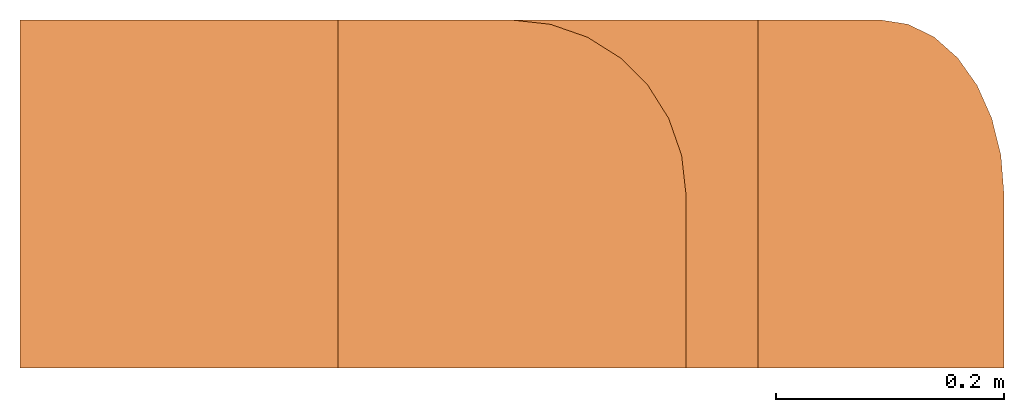
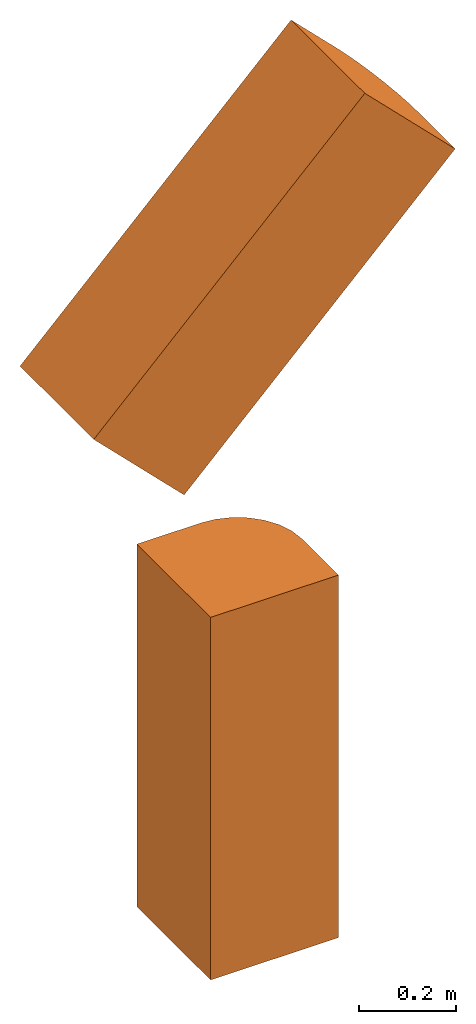
# One storey: 2 proxies.
"""IFC4 building model written with IfcOpenShell, lengths in feet."""

from ifc_helpers import new_model, entity, si_unit, converted_unit, frame, origin_with_axes, place, context, subcontext, project, spatial, polyline, outline, extrude, source, transform, mapped, type_object, element, save


model = new_model("IFC4")

# Units and contexts
model_context = context("Model", 3, precision=1e-05, world=origin_with_axes())
body_context = subcontext(model_context, "Body", "Model", "MODEL_VIEW")
ifc_project = project(units=[converted_unit("LENGTHUNIT", "foot", entity("IfcReal", 0.3048), si_unit("LENGTHUNIT", "METRE"), dimensions=[1, 0, 0, 0, 0, 0, 0]), converted_unit("AREAUNIT", "square foot", entity("IfcReal", 0.0929), si_unit("AREAUNIT", "SQUARE_METRE"), dimensions=[2, 0, 0, 0, 0, 0, 0]), converted_unit("VOLUMEUNIT", "cubic foot", entity("IfcReal", 0.02832), si_unit("VOLUMEUNIT", "CUBIC_METRE"), dimensions=[3, 0, 0, 0, 0, 0, 0])], contexts=[model_context])

# Site, building, storey
site_placement = place(None, origin_with_axes())
site = spatial("IfcSite", under=ifc_project, at=site_placement, CompositionType="ELEMENT")
building_placement = place(site_placement, origin_with_axes())
building = spatial("IfcBuilding", under=site, at=building_placement, CompositionType="ELEMENT")
storey_placement = place(building_placement, origin_with_axes())
storey = spatial("IfcBuildingStorey", under=building, at=storey_placement, Name="Level 1", CompositionType="ELEMENT", Elevation=0.0)

# Proxies
building_element_proxy_type_1 = type_object("IfcBuildingElementProxyType", Name="Generic Models 2:Generic Models 1", PredefinedType="NOTDEFINED")
shared_shape_1 = source(origin_with_axes(), body_context, "Body", "SweptSolid", [
    extrude(outline(polyline([(-0.689908607894667, -0.310091428908463), (-0.189908577271021, -0.310091428908463), (-0.189908577271021, -0.310091428908463), (-0.0786481136725018, -0.297555387059222), (0.0270332877091535, -0.26057586758312), (0.121836328091897, -0.201007155725962), (0.201007155725962, -0.121836328091897), (0.26057586758312, -0.0270332877091535), (0.297555387059222, 0.0786481136725018), (0.310091428908463, 0.189908577271021), (0.310091428908463, 0.189908577271021), (0.310091428908463, 0.689908607894667), (-0.689908607894667, 0.689908607894667), (-0.689908607894667, -0.310091428908463)])), frame((0.189908577271021, 0.189908577271021, 0.0), z_axis=(0.0, 0.0, 1.0), x_axis=(0.0, 1.0, 0.0)), (0.0, 0.0, 0.999999940395355), 2.99999996554402),
])
proxy_1_placement = place(storey_placement, origin_with_axes())
element("IfcBuildingElementProxy", 1, at=proxy_1_placement, inside=storey, type_object=building_element_proxy_type_1, Name="Generic Models 2:Generic Models 1", ObjectType="Generic Models 2:Generic Models 1", PredefinedType="NOTDEFINED", context=body_context, shape_type="MappedRepresentation", body=[
    mapped(shared_shape_1, transform((0.0, 0.0, 0.0), x_axis=(1.0, 0.0, 0.0), y_axis=(0.0, 1.0, 0.0), z_axis=(0.0, 0.0, 1.0), scale=1.0)),
])
building_element_proxy_type_2 = type_object("IfcBuildingElementProxyType", Name="Generic Models 1:Generic Models 1", PredefinedType="NOTDEFINED")
shared_shape_2 = source(origin_with_axes(), body_context, "Body", "SweptSolid", [
    extrude(outline(polyline([(-0.689908656782991, -0.310091477796787), (-0.189908650603507, -0.310091477796787), (-0.189908650603507, -0.310091477796787), (-0.0786481625608259, -0.29755536261506), (0.0270332388208294, -0.260575916471444), (0.121836254759411, -0.201007155725962), (0.2010071312818, -0.121836340313978), (0.260575794250633, -0.0270332999312346), (0.297555313726736, 0.0786481258945828), (0.310091355575977, 0.18990856504894), (0.310091355575977, 0.18990856504894), (0.310091355575977, 0.689908607894667), (-0.689908656782991, 0.689908607894667), (-0.689908656782991, -0.310091477796787)])), frame((0.487839035552943, 0.689908656782991, 0.224501564316549), z_axis=(0.70710676908493, -1.06114219633469e-08, 0.70710676908493), x_axis=(0.0, 1.0, 0.0)), (0.0, -2.85181886994224e-08, 1.0), 3.0000001794037),
])
proxy_2_placement = place(storey_placement, frame((-1.41421357399522, -0.500000006179484, 4.08055275443971), z_axis=(0.0, 0.0, 1.0), x_axis=(1.0, 0.0, 0.0)))
element("IfcBuildingElementProxy", 2, at=proxy_2_placement, inside=storey, type_object=building_element_proxy_type_2, Name="Generic Models 1:Generic Models 1", ObjectType="Generic Models 1:Generic Models 1", PredefinedType="NOTDEFINED", context=body_context, shape_type="MappedRepresentation", body=[
    mapped(shared_shape_2, transform((0.0, 0.0, 0.0), x_axis=(1.0, 0.0, 0.0), y_axis=(0.0, 1.0, 0.0), z_axis=(0.0, 0.0, 1.0), scale=1.0)),
])

save(model, "model.ifc")
